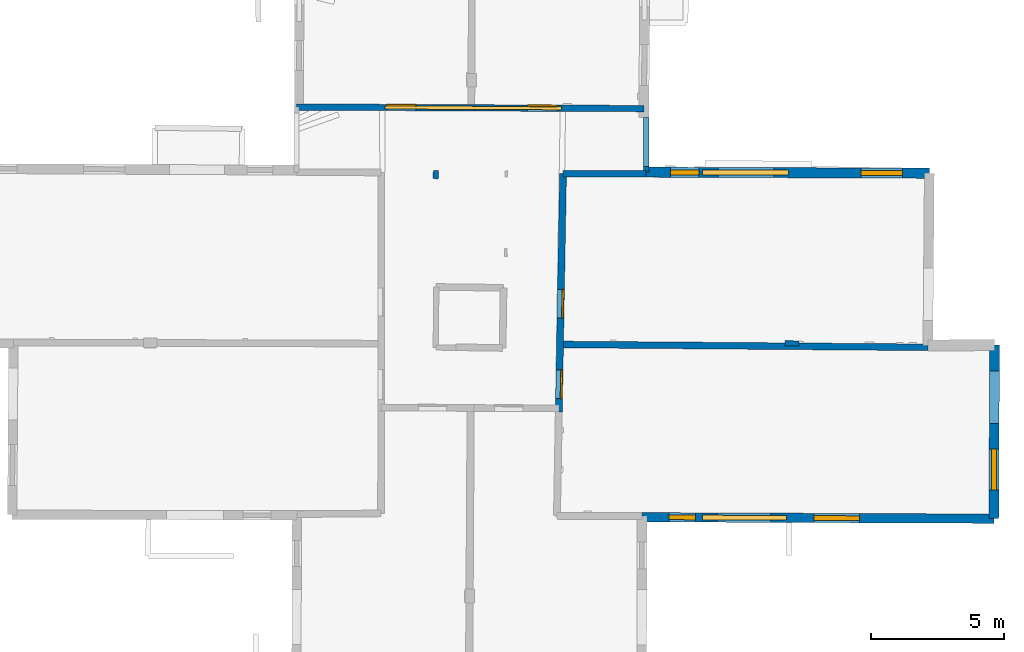
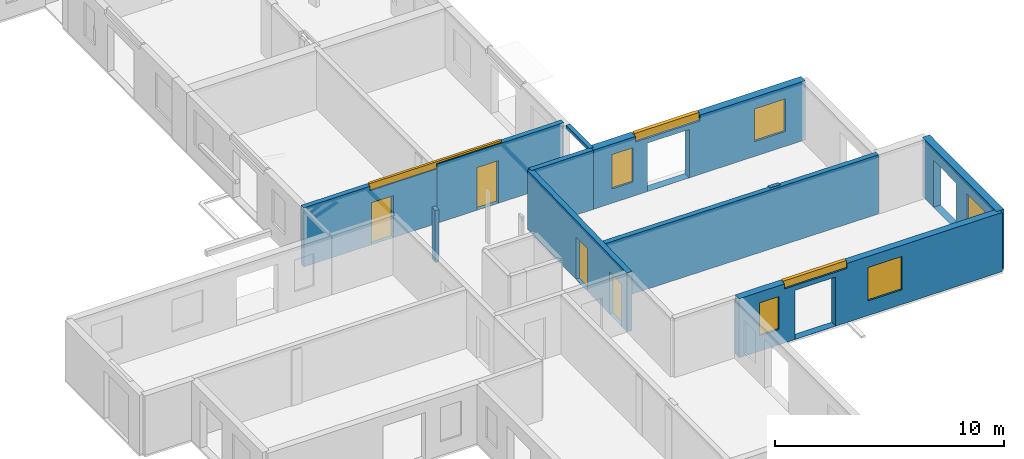
# One storey, part 4 of 14: 11 walls, 8 windows, 4 doors, 16 openings.
"""IFC2X3 building model written with IfcOpenShell, lengths in metres."""

from ifc_helpers import new_model, entity, si_unit, converted_unit, derived_unit, direction, frame, frame_2d, origin, origin_2d_with_axis, place, context, subcontext, project, spatial, polyline, rectangle, outline, extrude, source, transform, mapped, material, layer, layer_set, layer_usage, type_object, type_shapes, element, fill, save


model = new_model("IFC2X3")

# Units and contexts
model_context = context("Model", 3, precision=1e-05, world=origin(), true_north=direction((0.0, 1.0)))
body_context = subcontext(model_context, "Body", "Model", "MODEL_VIEW")
ifc_project = project(units=[si_unit("LENGTHUNIT", "METRE"), si_unit("AREAUNIT", "SQUARE_METRE"), si_unit("VOLUMEUNIT", "CUBIC_METRE"), converted_unit("PLANEANGLEUNIT", "DEGREE", entity("IfcRatioMeasure", 0.0174532925199433), si_unit("PLANEANGLEUNIT", "RADIAN"), dimensions=[0, 0, 0, 0, 0, 0, 0]), si_unit("MASSUNIT", "GRAM", prefix="KILO"), derived_unit("MASSDENSITYUNIT", [(si_unit("MASSUNIT", "GRAM", prefix="KILO"), 1), (si_unit("LENGTHUNIT", "METRE"), -3)]), derived_unit("MOMENTOFINERTIAUNIT", [(si_unit("LENGTHUNIT", "METRE"), 4)]), si_unit("TIMEUNIT", "SECOND"), si_unit("FREQUENCYUNIT", "HERTZ"), si_unit("THERMODYNAMICTEMPERATUREUNIT", "DEGREE_CELSIUS"), derived_unit("THERMALTRANSMITTANCEUNIT", [(si_unit("MASSUNIT", "GRAM", prefix="KILO"), 1), (si_unit("THERMODYNAMICTEMPERATUREUNIT", "KELVIN"), -1), (si_unit("TIMEUNIT", "SECOND"), -3)]), derived_unit("VOLUMETRICFLOWRATEUNIT", [(si_unit("LENGTHUNIT", "METRE"), 3), (si_unit("TIMEUNIT", "SECOND"), -1)]), si_unit("ELECTRICCURRENTUNIT", "AMPERE"), si_unit("ELECTRICVOLTAGEUNIT", "VOLT"), si_unit("POWERUNIT", "WATT"), si_unit("FORCEUNIT", "NEWTON", prefix="KILO"), si_unit("ILLUMINANCEUNIT", "LUX"), si_unit("LUMINOUSFLUXUNIT", "LUMEN"), si_unit("LUMINOUSINTENSITYUNIT", "CANDELA"), derived_unit("USERDEFINED", [(si_unit("MASSUNIT", "GRAM", prefix="KILO"), -1), (si_unit("LENGTHUNIT", "METRE"), -2), (si_unit("TIMEUNIT", "SECOND"), 3), (si_unit("LUMINOUSFLUXUNIT", "LUMEN"), 1)]), derived_unit("LINEARVELOCITYUNIT", [(si_unit("LENGTHUNIT", "METRE"), 1), (si_unit("TIMEUNIT", "SECOND"), -1)]), si_unit("PRESSUREUNIT", "PASCAL"), derived_unit("USERDEFINED", [(si_unit("LENGTHUNIT", "METRE"), -2), (si_unit("MASSUNIT", "GRAM", prefix="KILO"), 1), (si_unit("TIMEUNIT", "SECOND"), -2)]), derived_unit("LINEARFORCEUNIT", [(si_unit("MASSUNIT", "GRAM", prefix="KILO"), 1), (si_unit("LENGTHUNIT", "METRE"), 1), (si_unit("TIMEUNIT", "SECOND"), -2), (si_unit("LENGTHUNIT", "METRE"), -1)]), derived_unit("PLANARFORCEUNIT", [(si_unit("MASSUNIT", "GRAM", prefix="KILO"), 1), (si_unit("LENGTHUNIT", "METRE"), 1), (si_unit("TIMEUNIT", "SECOND"), -2), (si_unit("LENGTHUNIT", "METRE"), -2)])], contexts=[model_context])

# Site, building, storey
placement = place(None, origin())
site = spatial("IfcSite", under=ifc_project, at=placement, CompositionType="ELEMENT")
building = spatial("IfcBuilding", under=site, at=placement, CompositionType="ELEMENT")
storey_placement = place(placement, frame((0.0, 0.0, 8.83152770996094)))
storey = spatial("IfcBuildingStorey", under=building, at=storey_placement, Name="Level 4", CompositionType="ELEMENT", Elevation=8.83152770996094)

# Walls
ifc_material_1 = material(Name="Default wall")
ifc_layer_1 = layer(ifc_material_1, 0.25)
ifc_layer_set_1 = layer_set([ifc_layer_1], Name="wall_thickness_0.2500")
ifc_layer_usage_1 = layer_usage(ifc_layer_set_1, "AXIS2", "POSITIVE", -0.125)
wall_type_1 = type_object("IfcWallType", Name="wall_thickness_0.2500", PredefinedType="STANDARD", material=ifc_layer_set_1)
wall_1_placement = place(storey_placement, frame((9.66845822575518, 25.8263042048907, 0.0), z_axis=(0.0, 0.0, 1.0), x_axis=(0.99999421572371, -0.00340125258148584, 0.0)))
element("IfcWallStandardCase", 1, at=wall_1_placement, inside=storey, type_object=wall_type_1, material=ifc_layer_usage_1, Name="Wall:434", ObjectType="Wall", context=body_context, shape_type="SweptSolid", body=[
    extrude(outline(polyline([(3.12297434008637, -0.125), (3.12297434008637, 0.125), (0.0, 0.125), (0.0, -0.125), (3.12297434008637, -0.125)])), origin(), (0.0, 0.0, 1.0), 3.14668312072754),
])
wall_2_placement = place(storey_placement, frame((9.61974999378934, 19.4060515618813, 0.0), z_axis=(0.0, 0.0, 1.0), x_axis=(0.999970073833377, -0.00773637109179318, 0.0)))
element("IfcWallStandardCase", 2, at=wall_2_placement, inside=storey, type_object=wall_type_1, material=ifc_layer_usage_1, Name="Wall:496", ObjectType="Wall", context=body_context, shape_type="SweptSolid", body=[
    extrude(outline(polyline([(13.7612942004077, -0.125), (13.7612942004077, 0.125), (0.0, 0.125), (0.0, -0.125), (13.7612942004077, -0.125)])), origin(), (0.0, 0.0, 1.0), 3.14668312072754),
])

# Wall, openings, windows
ifc_layer_2 = layer(ifc_material_1, 0.349999994039536)
ifc_layer_set_2 = layer_set([ifc_layer_2], Name="wall_thickness_0.3500")
ifc_layer_usage_2 = layer_usage(ifc_layer_set_2, "AXIS2", "POSITIVE", -0.174999997019768)
wall_type_2 = type_object("IfcWallType", Name="wall_thickness_0.3500", PredefinedType="STANDARD", material=ifc_layer_set_2)
wall_3_placement = place(storey_placement, frame((12.6399811729569, 12.9138291215496, 0.0), z_axis=(0.0, 0.0, 1.0), x_axis=(0.99999176085378, -0.00405933794552658, 0.0)))
wall_3 = element("IfcWallStandardCase", 3, at=wall_3_placement, inside=storey, type_object=wall_type_2, material=ifc_layer_usage_2, Name="Wall:413", ObjectType="Wall", context=body_context, shape_type="SweptSolid", body=[
    extrude(outline(polyline([(13.2168866973757, -0.174999997019768), (13.2168866973757, 0.174999997019768), (0.0, 0.174999997019768), (0.0, -0.174999997019768), (13.2168866973757, -0.174999997019768)])), origin(), (0.0, 0.0, 1.0), 3.14668312072754),
])
opening_1_placement = place(wall_3_placement, frame((2.80680774821279, -0.174999997019768, 0.00547218322753906)))
element("IfcOpeningElement", 4, at=opening_1_placement, cuts=wall_3, Name="Opening : 2040 x 2615 : 324", ObjectType="Opening", context=body_context, shape_type="SweptSolid", body=[
    extrude(rectangle(XDim=2.04, YDim=2.615, at=frame_2d((1.3075, 1.02), x_axis=(0.0, 1.0))), frame((0.0, 0.0, 0.0), z_axis=(0.0, 1.0, 0.0), x_axis=(0.0, 0.0, 1.0)), (0.0, 0.0, 1.0), 0.349999994039536),
])
opening_2_placement = place(wall_3_placement, frame((2.27425254800309, -0.174999997019768, 2.87547206878662)))
opening_2 = element("IfcOpeningElement", 5, at=opening_2_placement, cuts=wall_3, Name="Opening : 3155 x 365 : 325", ObjectType="Opening", context=body_context, shape_type="SweptSolid", body=[
    extrude(rectangle(XDim=3.155, YDim=0.365, at=frame_2d((0.1825, 1.5775), x_axis=(0.0, 1.0))), frame((0.0, 0.0, 0.0), z_axis=(0.0, 1.0, 0.0), x_axis=(0.0, 0.0, 1.0)), (0.0, 0.0, 1.0), 0.349999994039536),
])
opening_3_placement = place(wall_3_placement, frame((1.01925258361104, -0.174999997019768, 0.82047176361084)))
opening_3 = element("IfcOpeningElement", 6, at=opening_3_placement, cuts=wall_3, Name="Opening : 980 x 1750 : 326", ObjectType="Opening", context=body_context, shape_type="SweptSolid", body=[
    extrude(rectangle(XDim=0.98, YDim=1.75, at=frame_2d((0.875, 0.49), x_axis=(0.0, 1.0))), frame((0.0, 0.0, 0.0), z_axis=(0.0, 1.0, 0.0), x_axis=(0.0, 0.0, 1.0)), (0.0, 0.0, 1.0), 0.349999994039536),
])
opening_4_placement = place(wall_3_placement, frame((6.46680818746066, -0.174999997019768, 0.780471801757812)))
opening_4 = element("IfcOpeningElement", 7, at=opening_4_placement, cuts=wall_3, Name="Opening : 1700 x 1780 : 327", ObjectType="Opening", context=body_context, shape_type="SweptSolid", body=[
    extrude(rectangle(XDim=1.7, YDim=1.78, at=frame_2d((0.89, 0.85), x_axis=(0.0, 1.0))), frame((0.0, 0.0, 0.0), z_axis=(0.0, 1.0, 0.0), x_axis=(0.0, 0.0, 1.0)), (0.0, 0.0, 1.0), 0.349999994039536),
])
ifc_material_2 = material(Name="Window Default")
window_style_1 = type_object("IfcWindowStyle", Name="Window : 3155 x 365mm", ConstructionType="NOTDEFINED", OperationType="NOTDEFINED", ParameterTakesPrecedence=False, Sizeable=False, material=ifc_material_2)
shared_shape_1 = source(origin(), body_context, "Body", "SweptSolid", [
    extrude(rectangle(XDim=0.174999997019768, YDim=3.155, at=origin_2d_with_axis()), frame((1.5775, 0.174999997019768, 0.0), z_axis=(0.0, 0.0, 1.0), x_axis=(0.0, 1.0, 0.0)), (0.0, 0.0, 1.0), 0.365),
])
type_shapes(window_style_1, [shared_shape_1])
window_1_placement = place(opening_2_placement, origin())
window_1 = element("IfcWindow", 8, at=window_1_placement, inside=storey, type_object=window_style_1, Name="Window : 3155 x 365mm : 175", ObjectType="Window : 3155 x 365mm", OverallHeight=0.365, OverallWidth=3.155, context=body_context, shape_type="MappedRepresentation", body=[
    mapped(shared_shape_1, transform((0.0, 0.0, 0.0), scale=1.0)),
])
fill(opening_2, window_1)
window_style_2 = type_object("IfcWindowStyle", Name="Window : 980 x 1750mm", ConstructionType="NOTDEFINED", OperationType="NOTDEFINED", ParameterTakesPrecedence=False, Sizeable=False, material=ifc_material_2)
shared_shape_2 = source(origin(), body_context, "Body", "SweptSolid", [
    extrude(rectangle(XDim=0.174999997019768, YDim=0.98, at=origin_2d_with_axis()), frame((0.49, 0.174999997019768, 0.0), z_axis=(0.0, 0.0, 1.0), x_axis=(0.0, 1.0, 0.0)), (0.0, 0.0, 1.0), 1.75),
])
type_shapes(window_style_2, [shared_shape_2])
window_2_placement = place(opening_3_placement, origin())
window_2 = element("IfcWindow", 9, at=window_2_placement, inside=storey, type_object=window_style_2, Name="Window : 980 x 1750mm : 176", ObjectType="Window : 980 x 1750mm", OverallHeight=1.75, OverallWidth=0.98, context=body_context, shape_type="MappedRepresentation", body=[
    mapped(shared_shape_2, transform((0.0, 0.0, 0.0), scale=1.0)),
])
fill(opening_3, window_2)
window_style_3 = type_object("IfcWindowStyle", Name="Window : 1700 x 1780mm", ConstructionType="NOTDEFINED", OperationType="NOTDEFINED", ParameterTakesPrecedence=False, Sizeable=False, material=ifc_material_2)
shared_shape_3 = source(origin(), body_context, "Body", "SweptSolid", [
    extrude(rectangle(XDim=0.174999997019768, YDim=1.7, at=origin_2d_with_axis()), frame((0.85, 0.174999997019768, 0.0), z_axis=(0.0, 0.0, 1.0), x_axis=(0.0, 1.0, 0.0)), (0.0, 0.0, 1.0), 1.78),
])
type_shapes(window_style_3, [shared_shape_3])
window_3_placement = place(opening_4_placement, origin())
window_3 = element("IfcWindow", 10, at=window_3_placement, inside=storey, type_object=window_style_3, Name="Window : 1700 x 1780mm : 177", ObjectType="Window : 1700 x 1780mm", OverallHeight=1.78, OverallWidth=1.7, context=body_context, shape_type="MappedRepresentation", body=[
    mapped(shared_shape_3, transform((0.0, 0.0, 0.0), scale=1.0)),
])
fill(opening_4, window_3)

# Walls
ifc_layer_3 = layer(ifc_material_1, 0.2)
ifc_layer_set_3 = layer_set([ifc_layer_3], Name="wall_thickness_0.2000")
ifc_layer_usage_3 = layer_usage(ifc_layer_set_3, "AXIS2", "POSITIVE", -0.1)
wall_type_3 = type_object("IfcWallType", Name="wall_thickness_0.2000", PredefinedType="STANDARD", material=ifc_layer_set_3)
wall_4_placement = place(storey_placement, frame((4.87834935668993, 25.6338678278629, 0.0), z_axis=(0.0, 0.0, 1.0), x_axis=(0.0519618195484596, 0.998649072151581, 0.0)))
element("IfcWallStandardCase", 11, at=wall_4_placement, inside=storey, type_object=wall_type_3, material=ifc_layer_usage_3, Name="Wall:467", ObjectType="Wall", context=body_context, shape_type="SweptSolid", body=[
    extrude(outline(polyline([(0.314998828653715, -0.1), (0.314998828653715, 0.1), (0.0, 0.1), (0.0, -0.1), (0.314998828653715, -0.1)])), origin(), (0.0, 0.0, 1.0), 2.76147270202637),
])
wall_5_placement = place(storey_placement, frame((18.0100419166156, 19.4519611512466, 0.0), z_axis=(0.0, 0.0, 1.0), x_axis=(0.9998548876575, -0.0170353640233349, 0.0)))
element("IfcWallStandardCase", 12, at=wall_5_placement, inside=storey, type_object=wall_type_3, material=ifc_layer_usage_3, Name="Wall:480", ObjectType="Wall", context=body_context, shape_type="SweptSolid", body=[
    extrude(outline(polyline([(0.52499950849345, -0.1), (0.52499950849345, 0.1), (0.0, 0.1), (0.0, -0.1), (0.52499950849345, -0.1)])), origin(), (0.0, 0.0, 1.0), 3.14668312072754),
])

# Wall, openings, door, window
ifc_layer_4 = layer(ifc_material_1, 0.239999994635582)
ifc_layer_set_4 = layer_set([ifc_layer_4], Name="wall_thickness_0.2400")
ifc_layer_usage_4 = layer_usage(ifc_layer_set_4, "AXIS2", "POSITIVE", -0.119999997317791)
wall_type_4 = type_object("IfcWallType", Name="wall_thickness_0.2400", PredefinedType="STANDARD", material=ifc_layer_set_4)
wall_6_placement = place(storey_placement, frame((-0.34147623908143, 28.3271579028498, 0.0), z_axis=(0.0, 0.0, 1.0), x_axis=(0.999990526963985, -0.00435269827711616, 0.0)))
wall_6 = element("IfcWallStandardCase", 13, at=wall_6_placement, inside=storey, type_object=wall_type_4, material=ifc_layer_usage_4, Name="Wall:439", ObjectType="Wall", context=body_context, shape_type="SweptSolid", body=[
    extrude(outline(polyline([(6.69130083657981, -0.119999997317791), (6.69130083657981, 0.119999997317791), (0.0, 0.119999997317791), (0.0, -0.119999997317791), (6.69130083657981, -0.119999997317791)])), origin(), (0.0, 0.0, 1.0), 3.14668312072754),
])
opening_5_placement = place(wall_6_placement, frame((3.39035502620319, -0.119999997317791, 0.00647258758544922)))
opening_5 = element("IfcOpeningElement", 14, at=opening_5_placement, cuts=wall_6, Name="Opening : 1100 x 2235 : 340", ObjectType="Opening", context=body_context, shape_type="SweptSolid", body=[
    extrude(rectangle(XDim=1.1, YDim=2.235, at=frame_2d((1.1175, 0.55), x_axis=(0.0, 1.0))), frame((0.0, 0.0, 0.0), z_axis=(0.0, 1.0, 0.0), x_axis=(0.0, 0.0, 1.0)), (0.0, 0.0, 1.0), 0.239999994635582),
])
opening_6_placement = place(wall_6_placement, frame((3.31348957378267, -0.119999997317791, 2.90547180175781)))
opening_6 = element("IfcOpeningElement", 15, at=opening_6_placement, cuts=wall_6, Name="Opening : 6645 x 335 : 341", ObjectType="Opening", context=body_context, shape_type="SweptSolid", body=[
    extrude(rectangle(XDim=6.645, YDim=0.335, at=frame_2d((0.1675, 3.3225), x_axis=(0.0, 1.0))), frame((0.0, 0.0, 0.0), z_axis=(0.0, 1.0, 0.0), x_axis=(0.0, 0.0, 1.0)), (0.0, 0.0, 1.0), 0.239999994635582),
])
ifc_material_3 = material(Name="Door Panel")
door_style_1 = type_object("IfcDoorStyle", Name="Door : 1100 x 2235mm", ConstructionType="NOTDEFINED", OperationType="SINGLE_SWING_RIGHT", ParameterTakesPrecedence=False, Sizeable=False, material=ifc_material_3)
shared_shape_4 = source(origin(), body_context, "Body", "SweptSolid", [
    extrude(rectangle(XDim=0.0599999986588955, YDim=1.1, at=origin_2d_with_axis()), frame((0.55, 0.209999995306134, 0.0), z_axis=(0.0, 0.0, 1.0), x_axis=(0.0, 1.0, 0.0)), (0.0, 0.0, 1.0), 2.235),
])
type_shapes(door_style_1, [shared_shape_4])
door_1_placement = place(opening_5_placement, origin())
door_1 = element("IfcDoor", 16, at=door_1_placement, inside=storey, type_object=door_style_1, Name="Door : 1100 x 2235mm : 65", ObjectType="Door : 1100 x 2235mm", OverallHeight=2.235, OverallWidth=1.1, context=body_context, shape_type="MappedRepresentation", body=[
    mapped(shared_shape_4, transform((0.0, 0.0, 0.0), scale=1.0)),
])
fill(opening_5, door_1)
window_style_4 = type_object("IfcWindowStyle", Name="Window : 6645 x 335mm", ConstructionType="NOTDEFINED", OperationType="NOTDEFINED", ParameterTakesPrecedence=False, Sizeable=False, material=ifc_material_2)
shared_shape_5 = source(origin(), body_context, "Body", "SweptSolid", [
    extrude(rectangle(XDim=0.119999997317791, YDim=6.645, at=origin_2d_with_axis()), frame((3.3225, 0.119999997317791, 0.0), z_axis=(0.0, 0.0, 1.0), x_axis=(0.0, 1.0, 0.0)), (0.0, 0.0, 1.0), 0.335),
])
type_shapes(window_style_4, [shared_shape_5])
window_4_placement = place(opening_6_placement, origin())
window_4 = element("IfcWindow", 17, at=window_4_placement, inside=storey, type_object=window_style_4, Name="Window : 6645 x 335mm : 183", ObjectType="Window : 6645 x 335mm", OverallHeight=0.335, OverallWidth=6.645, context=body_context, shape_type="MappedRepresentation", body=[
    mapped(shared_shape_5, transform((0.0, 0.0, 0.0), scale=1.0)),
])
fill(opening_6, window_4)

# Wall, opening, door
wall_7_placement = place(storey_placement, frame((6.34976121056457, 28.2980326892268, 0.0), z_axis=(0.0, 0.0, 1.0), x_axis=(0.999990526881923, -0.00435271713009269, 0.0)))
wall_7 = element("IfcWallStandardCase", 18, at=wall_7_placement, inside=storey, type_object=wall_type_4, material=ifc_layer_usage_4, Name="Wall:440", ObjectType="Wall", context=body_context, shape_type="SweptSolid", body=[
    extrude(outline(polyline([(6.36350031896359, -0.119999997317791), (6.36350031896359, 0.119999997317791), (0.0, 0.119999997317791), (0.0, -0.119999997317791), (6.36350031896359, -0.119999997317791)])), origin(), (0.0, 0.0, 1.0), 3.14668312072754),
])
opening_7_placement = place(wall_7_placement, frame((1.99216296557924, -0.119999997317791, 0.00547218322753906)))
opening_7 = element("IfcOpeningElement", 19, at=opening_7_placement, cuts=wall_7, Name="Opening : 1095 x 2265 : 342", ObjectType="Opening", context=body_context, shape_type="SweptSolid", body=[
    extrude(rectangle(XDim=1.095, YDim=2.265, at=frame_2d((1.1325, 0.5475), x_axis=(0.0, 1.0))), frame((0.0, 0.0, 0.0), z_axis=(0.0, 1.0, 0.0), x_axis=(0.0, 0.0, 1.0)), (0.0, 0.0, 1.0), 0.239999994635582),
])
door_style_2 = type_object("IfcDoorStyle", Name="Door : 1095 x 2265mm", ConstructionType="NOTDEFINED", OperationType="SINGLE_SWING_RIGHT", ParameterTakesPrecedence=False, Sizeable=False, material=ifc_material_3)
shared_shape_6 = source(origin(), body_context, "Body", "SweptSolid", [
    extrude(rectangle(XDim=0.0599999986588955, YDim=1.095, at=origin_2d_with_axis()), frame((0.5475, 0.209999995306134, 0.0), z_axis=(0.0, 0.0, 1.0), x_axis=(0.0, 1.0, 0.0)), (0.0, 0.0, 1.0), 2.265),
])
type_shapes(door_style_2, [shared_shape_6])
door_2_placement = place(opening_7_placement, origin())
door_2 = element("IfcDoor", 20, at=door_2_placement, inside=storey, type_object=door_style_2, Name="Door : 1095 x 2265mm : 66", ObjectType="Door : 1095 x 2265mm", OverallHeight=2.265, OverallWidth=1.095, context=body_context, shape_type="MappedRepresentation", body=[
    mapped(shared_shape_6, transform((0.0, 0.0, 0.0), scale=1.0)),
])
fill(opening_7, door_2)

# Wall, openings, doors
ifc_layer_5 = layer(ifc_material_1, 0.259999990463257)
ifc_layer_set_5 = layer_set([ifc_layer_5], Name="wall_thickness_0.2600")
ifc_layer_usage_5 = layer_usage(ifc_layer_set_5, "AXIS2", "POSITIVE", -0.129999995231628)
wall_type_5 = type_object("IfcWallType", Name="wall_thickness_0.2600", PredefinedType="STANDARD", material=ifc_layer_set_5)
wall_8_placement = place(storey_placement, frame((9.66845838296837, 25.8263067443942, 0.0), z_axis=(0.0, 0.0, 1.0), x_axis=(-0.0177427097770413, -0.999842585735259, 0.0)))
wall_8 = element("IfcWallStandardCase", 21, at=wall_8_placement, inside=storey, type_object=wall_type_5, material=ifc_layer_usage_5, Name="Wall:478", ObjectType="Wall", context=body_context, shape_type="SweptSolid", body=[
    extrude(outline(polyline([(8.95021565431181, -0.129999995231628), (8.95021565431181, 0.129999995231628), (0.0, 0.129999995231628), (0.0, -0.129999995231628), (8.95021565431181, -0.129999995231628)])), origin(), (0.0, 0.0, 1.0), 3.14668312072754),
])
opening_8_placement = place(wall_8_placement, frame((4.35227052713762, -0.129999995231628, 0.00547218322753906)))
opening_8 = element("IfcOpeningElement", 22, at=opening_8_placement, cuts=wall_8, Name="Opening : 1075 x 2250 : 374", ObjectType="Opening", context=body_context, shape_type="SweptSolid", body=[
    extrude(rectangle(XDim=1.075, YDim=2.25, at=frame_2d((1.125, 0.5375), x_axis=(0.0, 1.0))), frame((0.0, 0.0, 0.0), z_axis=(0.0, 1.0, 0.0), x_axis=(0.0, 0.0, 1.0)), (0.0, 0.0, 1.0), 0.259999990463257),
])
opening_9_placement = place(wall_8_placement, frame((7.37737057978974, -0.129999995231628, 0.00947284698486328)))
opening_9 = element("IfcOpeningElement", 23, at=opening_9_placement, cuts=wall_8, Name="Opening : 1075 x 2250 : 375", ObjectType="Opening", context=body_context, shape_type="SweptSolid", body=[
    extrude(rectangle(XDim=1.075, YDim=2.25, at=frame_2d((1.125, 0.5375), x_axis=(0.0, 1.0))), frame((0.0, 0.0, 0.0), z_axis=(0.0, 1.0, 0.0), x_axis=(0.0, 0.0, 1.0)), (0.0, 0.0, 1.0), 0.259999990463257),
])
door_style_3 = type_object("IfcDoorStyle", Name="Door : 1075 x 2250mm", ConstructionType="NOTDEFINED", OperationType="SINGLE_SWING_RIGHT", ParameterTakesPrecedence=False, Sizeable=False, material=ifc_material_3)
shared_shape_7 = source(origin(), body_context, "Body", "SweptSolid", [
    extrude(rectangle(XDim=0.0599999986588955, YDim=1.075, at=origin_2d_with_axis()), frame((0.5375, 0.209999995306134, 0.0), z_axis=(0.0, 0.0, 1.0), x_axis=(0.0, 1.0, 0.0)), (0.0, 0.0, 1.0), 2.25),
])
type_shapes(door_style_3, [shared_shape_7])
door_3_placement = place(opening_8_placement, origin())
door_3 = element("IfcDoor", 24, at=door_3_placement, inside=storey, type_object=door_style_3, Name="Door : 1075 x 2250mm : 69", ObjectType="Door : 1075 x 2250mm", OverallHeight=2.25, OverallWidth=1.075, context=body_context, shape_type="MappedRepresentation", body=[
    mapped(shared_shape_7, transform((0.0, 0.0, 0.0), scale=1.0)),
])
fill(opening_8, door_3)
door_4_placement = place(opening_9_placement, origin())
door_4 = element("IfcDoor", 25, at=door_4_placement, inside=storey, type_object=door_style_3, Name="Door : 1075 x 2250mm : 70", ObjectType="Door : 1075 x 2250mm", OverallHeight=2.25, OverallWidth=1.075, context=body_context, shape_type="MappedRepresentation", body=[
    mapped(shared_shape_7, transform((0.0, 0.0, 0.0), scale=1.0)),
])
fill(opening_9, door_4)

# Wall, openings, windows
ifc_layer_6 = layer(ifc_material_1, 0.379999995231628)
ifc_layer_set_6 = layer_set([ifc_layer_6], Name="wall_thickness_0.3800")
ifc_layer_usage_6 = layer_usage(ifc_layer_set_6, "AXIS2", "POSITIVE", -0.189999997615814)
wall_type_6 = type_object("IfcWallType", Name="wall_thickness_0.3800", PredefinedType="STANDARD", material=ifc_layer_set_6)
wall_9_placement = place(storey_placement, frame((12.7917343128181, 25.8823242905917, 0.0), z_axis=(0.0, 0.0, 1.0), x_axis=(0.999992406804646, -0.00389696459451747, 0.0)))
wall_9 = element("IfcWallStandardCase", 26, at=wall_9_placement, inside=storey, type_object=wall_type_6, material=ifc_layer_usage_6, Name="Wall:386", ObjectType="Wall", context=body_context, shape_type="SweptSolid", body=[
    extrude(outline(polyline([(10.6424853667449, -0.189999997615814), (10.6424853667449, 0.189999997615814), (0.0, 0.189999997615814), (0.0, -0.189999997615814), (10.6424853667449, -0.189999997615814)])), origin(), (0.0, 0.0, 1.0), 3.14668312072754),
])
opening_10_placement = place(wall_9_placement, frame((2.69947290563911, -0.189999997615814, 0.00547218322753906)))
element("IfcOpeningElement", 27, at=opening_10_placement, cuts=wall_9, Name="Opening : 2105 x 2570 : 307", ObjectType="Opening", context=body_context, shape_type="SweptSolid", body=[
    extrude(rectangle(XDim=2.105, YDim=2.57, at=frame_2d((1.285, 1.0525), x_axis=(0.0, 1.0))), frame((0.0, 0.0, 0.0), z_axis=(0.0, 1.0, 0.0), x_axis=(0.0, 0.0, 1.0)), (0.0, 0.0, 1.0), 0.379999995231628),
])
opening_11_placement = place(wall_9_placement, frame((8.07895692922442, -0.189999997615814, 0.790472030639648)))
opening_11 = element("IfcOpeningElement", 28, at=opening_11_placement, cuts=wall_9, Name="Opening : 1550 x 1740 : 308", ObjectType="Opening", context=body_context, shape_type="SweptSolid", body=[
    extrude(rectangle(XDim=1.55, YDim=1.74, at=frame_2d((0.87, 0.775), x_axis=(0.0, 1.0))), frame((0.0, 0.0, 0.0), z_axis=(0.0, 1.0, 0.0), x_axis=(0.0, 0.0, 1.0)), (0.0, 0.0, 1.0), 0.379999995231628),
])
opening_12_placement = place(wall_9_placement, frame((2.1139572542469, -0.189999997615814, 2.84547233581543)))
opening_12 = element("IfcOpeningElement", 29, at=opening_12_placement, cuts=wall_9, Name="Opening : 3240 x 395 : 309", ObjectType="Opening", context=body_context, shape_type="SweptSolid", body=[
    extrude(rectangle(XDim=3.24, YDim=0.395, at=frame_2d((0.1975, 1.62), x_axis=(0.0, 1.0))), frame((0.0, 0.0, 0.0), z_axis=(0.0, 1.0, 0.0), x_axis=(0.0, 0.0, 1.0)), (0.0, 0.0, 1.0), 0.379999995231628),
])
opening_13_placement = place(wall_9_placement, frame((0.914910721642128, -0.189999997615814, 0.760472297668457)))
opening_13 = element("IfcOpeningElement", 30, at=opening_13_placement, cuts=wall_9, Name="Opening : 1070 x 1830 : 310", ObjectType="Opening", context=body_context, shape_type="SweptSolid", body=[
    extrude(rectangle(XDim=1.07, YDim=1.83, at=frame_2d((0.915, 0.535), x_axis=(0.0, 1.0))), frame((0.0, 0.0, 0.0), z_axis=(0.0, 1.0, 0.0), x_axis=(0.0, 0.0, 1.0)), (0.0, 0.0, 1.0), 0.379999995231628),
])
window_style_5 = type_object("IfcWindowStyle", Name="Window : 1070 x 1830mm", ConstructionType="NOTDEFINED", OperationType="NOTDEFINED", ParameterTakesPrecedence=False, Sizeable=False, material=ifc_material_2)
shared_shape_8 = source(origin(), body_context, "Body", "SweptSolid", [
    extrude(rectangle(XDim=0.180000007152557, YDim=1.07, at=origin_2d_with_axis()), frame((0.535, 0.180000007152557, 0.0), z_axis=(0.0, 0.0, 1.0), x_axis=(0.0, 1.0, 0.0)), (0.0, 0.0, 1.0), 1.83),
])
type_shapes(window_style_5, [shared_shape_8])
window_5_placement = place(opening_13_placement, origin())
window_5 = element("IfcWindow", 31, at=window_5_placement, inside=storey, type_object=window_style_5, Name="Window : 1070 x 1830mm : 167", ObjectType="Window : 1070 x 1830mm", OverallHeight=1.83, OverallWidth=1.07, context=body_context, shape_type="MappedRepresentation", body=[
    mapped(shared_shape_8, transform((0.0, 0.0, 0.0), scale=1.0)),
])
fill(opening_13, window_5)
window_style_6 = type_object("IfcWindowStyle", Name="Window : 1550 x 1740mm", ConstructionType="NOTDEFINED", OperationType="NOTDEFINED", ParameterTakesPrecedence=False, Sizeable=False, material=ifc_material_2)
shared_shape_9 = source(origin(), body_context, "Body", "SweptSolid", [
    extrude(rectangle(XDim=0.189999997615814, YDim=1.55, at=origin_2d_with_axis()), frame((0.775, 0.189999997615814, 0.0), z_axis=(0.0, 0.0, 1.0), x_axis=(0.0, 1.0, 0.0)), (0.0, 0.0, 1.0), 1.74),
])
type_shapes(window_style_6, [shared_shape_9])
window_6_placement = place(opening_11_placement, origin())
window_6 = element("IfcWindow", 32, at=window_6_placement, inside=storey, type_object=window_style_6, Name="Window : 1550 x 1740mm : 165", ObjectType="Window : 1550 x 1740mm", OverallHeight=1.74, OverallWidth=1.55, context=body_context, shape_type="MappedRepresentation", body=[
    mapped(shared_shape_9, transform((0.0, 0.0, 0.0), scale=1.0)),
])
fill(opening_11, window_6)
window_style_7 = type_object("IfcWindowStyle", Name="Window : 3240 x 395mm", ConstructionType="NOTDEFINED", OperationType="NOTDEFINED", ParameterTakesPrecedence=False, Sizeable=False, material=ifc_material_2)
shared_shape_10 = source(origin(), body_context, "Body", "SweptSolid", [
    extrude(rectangle(XDim=0.189999997615814, YDim=3.24, at=origin_2d_with_axis()), frame((1.62, 0.189999997615814, 0.0), z_axis=(0.0, 0.0, 1.0), x_axis=(0.0, 1.0, 0.0)), (0.0, 0.0, 1.0), 0.395),
])
type_shapes(window_style_7, [shared_shape_10])
window_7_placement = place(opening_12_placement, origin())
window_7 = element("IfcWindow", 33, at=window_7_placement, inside=storey, type_object=window_style_7, Name="Window : 3240 x 395mm : 166", ObjectType="Window : 3240 x 395mm", OverallHeight=0.395, OverallWidth=3.24, context=body_context, shape_type="MappedRepresentation", body=[
    mapped(shared_shape_10, transform((0.0, 0.0, 0.0), scale=1.0)),
])
fill(opening_12, window_7)

# Wall, openings, window
ifc_layer_7 = layer(ifc_material_1, 0.370000004768372)
ifc_layer_set_7 = layer_set([ifc_layer_7], Name="wall_thickness_0.3700")
ifc_layer_usage_7 = layer_usage(ifc_layer_set_7, "AXIS2", "POSITIVE", -0.185000002384186)
wall_type_7 = type_object("IfcWallType", Name="wall_thickness_0.3700", PredefinedType="STANDARD", material=ifc_layer_set_7)
wall_10_placement = place(storey_placement, frame((25.8849670886643, 19.3859887700365, 0.0), z_axis=(0.0, 0.0, 1.0), x_axis=(-0.00432274513407692, -0.999990656893606, 0.0)))
wall_10 = element("IfcWallStandardCase", 34, at=wall_10_placement, inside=storey, type_object=wall_type_7, material=ifc_layer_usage_7, Name="Wall:493", ObjectType="Wall", context=body_context, shape_type="SweptSolid", body=[
    extrude(outline(polyline([(6.52587312097473, -0.185000002384186), (6.52587312097473, 0.185000002384186), (0.0, 0.185000002384186), (0.0, -0.185000002384186), (6.52587312097473, -0.185000002384186)])), origin(), (0.0, 0.0, 1.0), 3.14668312072754),
])
opening_14_placement = place(wall_10_placement, frame((0.972667255665291, -0.185000002384186, 0.00547218322753906)))
element("IfcOpeningElement", 35, at=opening_14_placement, cuts=wall_10, Name="Opening : 1980 x 2495 : 380", ObjectType="Opening", context=body_context, shape_type="SweptSolid", body=[
    extrude(rectangle(XDim=1.98, YDim=2.495, at=frame_2d((1.2475, 0.99), x_axis=(0.0, 1.0))), frame((0.0, 0.0, 0.0), z_axis=(0.0, 1.0, 0.0), x_axis=(0.0, 0.0, 1.0)), (0.0, 0.0, 1.0), 0.370000004768372),
])
opening_15_placement = place(wall_10_placement, frame((3.91266759275857, -0.185000002384186, 0.800472259521484)))
opening_15 = element("IfcOpeningElement", 36, at=opening_15_placement, cuts=wall_10, Name="Opening : 1535 x 1710 : 381", ObjectType="Opening", context=body_context, shape_type="SweptSolid", body=[
    extrude(rectangle(XDim=1.535, YDim=1.71, at=frame_2d((0.855, 0.7675), x_axis=(0.0, 1.0))), frame((0.0, 0.0, 0.0), z_axis=(0.0, 1.0, 0.0), x_axis=(0.0, 0.0, 1.0)), (0.0, 0.0, 1.0), 0.370000004768372),
])
window_style_8 = type_object("IfcWindowStyle", Name="Window : 1535 x 1710mm", ConstructionType="NOTDEFINED", OperationType="NOTDEFINED", ParameterTakesPrecedence=False, Sizeable=False, material=ifc_material_2)
shared_shape_11 = source(origin(), body_context, "Body", "SweptSolid", [
    extrude(rectangle(XDim=0.185000002384186, YDim=1.535, at=origin_2d_with_axis()), frame((0.7675, 0.185000002384186, 0.0), z_axis=(0.0, 0.0, 1.0), x_axis=(0.0, 1.0, 0.0)), (0.0, 0.0, 1.0), 1.71),
])
type_shapes(window_style_8, [shared_shape_11])
window_8_placement = place(opening_15_placement, origin())
window_8 = element("IfcWindow", 37, at=window_8_placement, inside=storey, type_object=window_style_8, Name="Window : 1535 x 1710mm : 207", ObjectType="Window : 1535 x 1710mm", OverallHeight=1.71, OverallWidth=1.535, context=body_context, shape_type="MappedRepresentation", body=[
    mapped(shared_shape_11, transform((0.0, 0.0, 0.0), scale=1.0)),
])
fill(opening_15, window_8)

# Wall, opening
ifc_layer_8 = layer(ifc_material_1, 0.200000002980232)
ifc_layer_set_8 = layer_set([ifc_layer_8], Name="wall_thickness_0.2000")
ifc_layer_usage_8 = layer_usage(ifc_layer_set_8, "AXIS2", "POSITIVE", -0.100000001490116)
wall_type_8 = type_object("IfcWallType", Name="wall_thickness_0.2000", PredefinedType="STANDARD", material=ifc_layer_set_8)
wall_11_placement = place(storey_placement, frame((12.8016162938819, 27.9399790145137, 0.0), z_axis=(0.0, 0.0, 1.0), x_axis=(-0.00480201729702978, -0.999988470248472, 0.0)))
wall_11 = element("IfcWallStandardCase", 38, at=wall_11_placement, inside=storey, type_object=wall_type_8, material=ifc_layer_usage_8, Name="Wall:464", ObjectType="Wall", context=body_context, shape_type="SweptSolid", body=[
    extrude(outline(polyline([(2.05768096637156, -0.100000001490116), (2.05768096637156, 0.100000001490116), (0.0, 0.100000001490116), (0.0, -0.100000001490116), (2.05768096637156, -0.100000001490116)])), origin(), (0.0, 0.0, 1.0), 3.14668312072754),
])
opening_16_placement = place(wall_11_placement, frame((-0.0943348249206959, -0.100000001490116, 0.00547218322753906)))
element("IfcOpeningElement", 39, at=opening_16_placement, cuts=wall_11, Name="Opening : 1945 x 2940 : 363", ObjectType="Opening", context=body_context, shape_type="SweptSolid", body=[
    extrude(rectangle(XDim=1.945, YDim=2.94, at=frame_2d((1.47, 0.9725), x_axis=(0.0, 1.0))), frame((0.0, 0.0, 0.0), z_axis=(0.0, 1.0, 0.0), x_axis=(0.0, 0.0, 1.0)), (0.0, 0.0, 1.0), 0.200000002980232),
])

save(model, "model.ifc")
